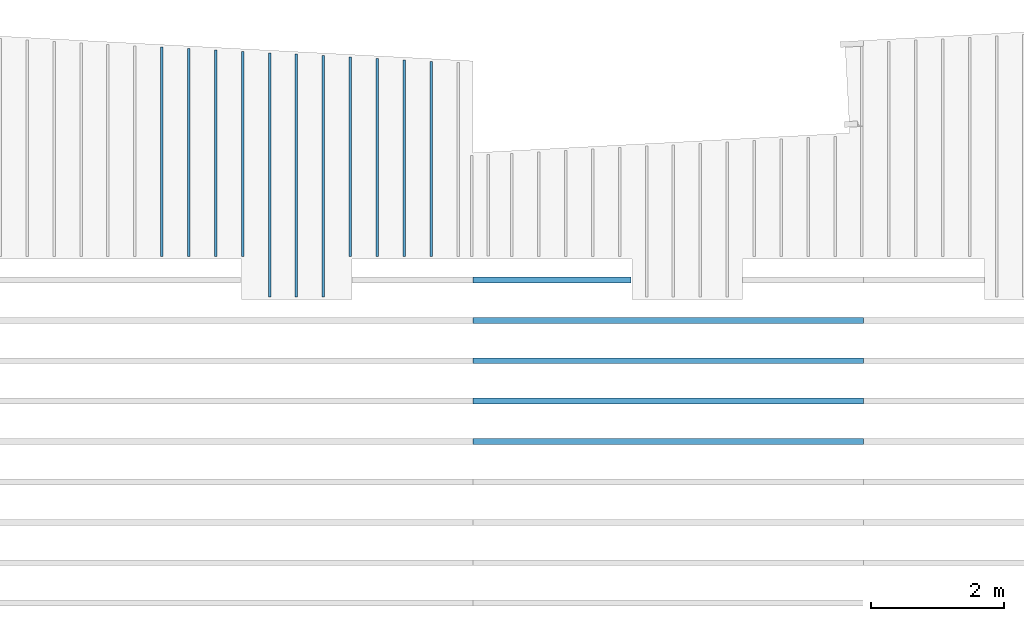
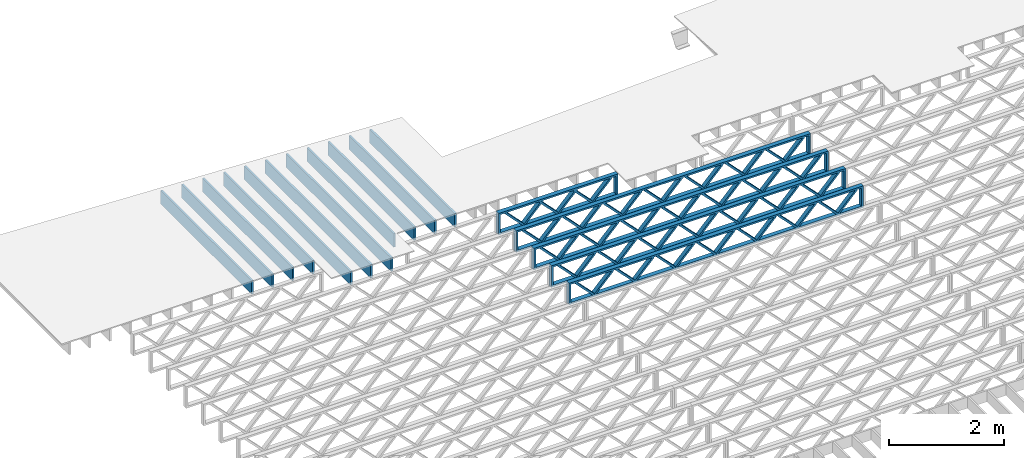
# One storey, part 4 of 12: 16 beams, 2 elements without a shape of their own.
"""IFC4 building model written with IfcOpenShell, lengths in feet."""

import ifcopenshell
import ifcopenshell.guid

model = None  # the IFC model being written
_history = None  # IfcOwnerHistory: only IFC2X3 demands one
_inside = {}  # id of a spatial element -> (the spatial element, [elements in it])
_under = {}  # id of a project, library or spatial element -> (it, [spatial elements below it])
_declared = {}  # id of a project -> (the project, [libraries it declares])
_typed = {}  # id of a type object -> (the type object, [elements of that type])
_made_of = {}  # id of a material, layer set ... -> (it, [elements and type objects made of it])


def new_model(schema):
    """Start an empty IFC model of exactly this schema.

    Asked for "IFC4X3", IfcOpenShell would pick the latest addendum, in which some entities
    have other attributes; the version numbers below select the first issue.
    IFC2X3 requires an IfcOwnerHistory on every rooted entity: one is made here for all.
    """
    global model, _history
    if schema == "IFC4X3":
        model = ifcopenshell.file(schema_version=(4, 3, 0, 0))
    else:
        model = ifcopenshell.file(schema=schema)
    _inside.clear()
    _under.clear()
    _declared.clear()
    _typed.clear()
    _made_of.clear()
    _history = None
    if model.schema == "IFC2X3":
        org = make("IfcOrganization", Name="unknown")
        user = make(
            "IfcPersonAndOrganization",
            ThePerson=make("IfcPerson", FamilyName="unknown"),
            TheOrganization=org,
        )
        app = make(
            "IfcApplication",
            ApplicationDeveloper=org,
            Version="unknown",
            ApplicationFullName="unknown",
            ApplicationIdentifier="unknown",
        )
        _history = make(
            "IfcOwnerHistory",
            OwningUser=user,
            OwningApplication=app,
            ChangeAction="ADDED",
            CreationDate=0,
        )
    return model


def make(cls, **values):
    """One entity of the class cls with the attributes given. An attribute that is None is left unset."""
    return model.create_entity(
        cls, **{name: value for name, value in values.items() if value is not None}
    )


def entity(cls, *values):
    """Any entity or typed value of the class cls, its attributes in the order of the schema. None: left unset."""
    e = model.create_entity(cls)
    for i, value in enumerate(values):
        if value is not None:
            e[i] = value
    return e


def rooted(cls, **values):
    """An entity with a GlobalId (a new one), such as an element, a storey or a relation."""
    return make(cls, GlobalId=ifcopenshell.guid.new(), OwnerHistory=_history, **values)


def si_unit(unit_type, name, prefix=None):
    """IfcSIUnit, for example si_unit("LENGTHUNIT", "METRE", prefix="MILLI")."""
    return make("IfcSIUnit", UnitType=unit_type, Prefix=prefix, Name=name)


def converted_unit(unit_type, name, factor, base, dimensions=None, offset=None):
    """IfcConversionBasedUnit, such as the inch: factor (a typed value) times the base unit."""
    return make(
        "IfcConversionBasedUnit"
        if offset is None
        else "IfcConversionBasedUnitWithOffset",
        ConversionOffset=offset,
        Dimensions=None
        if dimensions is None
        else entity("IfcDimensionalExponents", *dimensions),
        UnitType=unit_type,
        Name=name,
        ConversionFactor=make(
            "IfcMeasureWithUnit", ValueComponent=factor, UnitComponent=base
        ),
    )


def derived_unit(unit_type, elements):
    """IfcDerivedUnit: a product of units, each with its exponent."""
    return make(
        "IfcDerivedUnit",
        Elements=[
            make("IfcDerivedUnitElement", Unit=unit, Exponent=power)
            for unit, power in elements
        ],
        UnitType=unit_type,
    )


def assignment(units):
    """IfcUnitAssignment: the units of a project."""
    return None if units is None else make("IfcUnitAssignment", Units=units)


def point(xyz):
    """IfcCartesianPoint."""
    return None if xyz is None else make("IfcCartesianPoint", Coordinates=xyz)


def direction(xyz):
    """IfcDirection."""
    return None if xyz is None else make("IfcDirection", DirectionRatios=xyz)


def frame(location, z_axis=None, x_axis=None):
    """IfcAxis2Placement3D, a coordinate frame: its origin and axes. An axis left out is left unset."""
    return make(
        "IfcAxis2Placement3D",
        Location=point(location),
        Axis=direction(z_axis),
        RefDirection=direction(x_axis),
    )


def frame_2d(location, x_axis=None):
    """IfcAxis2Placement2D, a coordinate frame in the plane: its origin and x axis."""
    return make(
        "IfcAxis2Placement2D", Location=point(location), RefDirection=direction(x_axis)
    )


def origin():
    """The frame at (0, 0, 0) with its axes left unset."""
    return frame((0.0, 0.0, 0.0))


def origin_2d_with_axis():
    """The frame at (0, 0) in the plane with the x axis (1, 0) written out."""
    return frame_2d((0.0, 0.0), x_axis=(1.0, 0.0))


def place(relative_to, where):
    """IfcLocalPlacement: puts the frame where relative to a parent placement (None: the world)."""
    return make(
        "IfcLocalPlacement", PlacementRelTo=relative_to, RelativePlacement=where
    )


def context(
    kind, dimensions, precision=None, world=None, true_north=None, identifier=None
):
    """IfcGeometricRepresentationContext, for example the 3D "Model" context."""
    return make(
        "IfcGeometricRepresentationContext",
        ContextIdentifier=identifier,
        ContextType=kind,
        CoordinateSpaceDimension=dimensions,
        Precision=precision,
        WorldCoordinateSystem=world,
        TrueNorth=true_north,
    )


def subcontext(parent, identifier, kind, view, scale=None):
    """IfcGeometricRepresentationSubContext, for example "Body" below "Model"."""
    return make(
        "IfcGeometricRepresentationSubContext",
        ContextIdentifier=identifier,
        ContextType=kind,
        ParentContext=parent,
        TargetScale=scale,
        TargetView=view,
    )


def project(units=None, contexts=None):
    """IfcProject with its units and contexts."""
    return rooted(
        "IfcProject",
        Name="project",
        RepresentationContexts=contexts,
        UnitsInContext=assignment(units),
    )


def spatial(cls, under=None, at=None, **own):
    """A site, building, storey or space (cls), placed at a placement, below another one or the project."""
    s = rooted(cls, ObjectPlacement=at, **own)
    if under is not None:
        _under.setdefault(under.id(), (under, []))[1].append(s)
    return s


def profile(cls, at=None, kind="AREA", **sizes):
    """A parametric profile (cls). Its sizes go by their IFC names, for example OverallWidth=200.0."""
    return make(cls, ProfileType=kind, Position=at, **sizes)


def rectangle(**sizes):
    """IfcRectangleProfileDef."""
    return profile("IfcRectangleProfileDef", **sizes)


def extrude(swept, where, along, depth):
    """IfcExtrudedAreaSolid: the profile swept, set in the frame where, extruded along a direction by depth."""
    return make(
        "IfcExtrudedAreaSolid",
        SweptArea=swept,
        Position=where,
        ExtrudedDirection=direction(along),
        Depth=depth,
    )


def shape(context_of_items, identifier, shape_type, items):
    """IfcShapeRepresentation: the items that make up one representation, for example the "Body"."""
    return make(
        "IfcShapeRepresentation",
        ContextOfItems=context_of_items,
        RepresentationIdentifier=identifier,
        RepresentationType=shape_type,
        Items=items,
    )


def source(mapping_origin, context_of_items, identifier, shape_type, items):
    """IfcRepresentationMap: a shape defined once, which mapped items show again and again."""
    return make(
        "IfcRepresentationMap",
        MappingOrigin=mapping_origin,
        MappedRepresentation=shape(context_of_items, identifier, shape_type, items),
    )


def transform(
    local_origin,
    x_axis=None,
    y_axis=None,
    z_axis=None,
    scale=None,
    scale2=None,
    scale3=None,
    uniform=True,
):
    """IfcCartesianTransformationOperator3D, or its non-uniform kind. x_axis, y_axis, z_axis: its Axis1, 2, 3."""
    if uniform:
        return make(
            "IfcCartesianTransformationOperator3D",
            Axis1=direction(x_axis),
            Axis2=direction(y_axis),
            LocalOrigin=point(local_origin),
            Scale=scale,
            Axis3=direction(z_axis),
        )
    return make(
        "IfcCartesianTransformationOperator3DnonUniform",
        Axis1=direction(x_axis),
        Axis2=direction(y_axis),
        LocalOrigin=point(local_origin),
        Scale=scale,
        Axis3=direction(z_axis),
        Scale2=scale2,
        Scale3=scale3,
    )


def mapped(mapping_source, mapping_target):
    """IfcMappedItem: shows the shape of a source again, moved by a transform."""
    return make(
        "IfcMappedItem", MappingSource=mapping_source, MappingTarget=mapping_target
    )


def material(Name=None, Category=None):
    """IfcMaterial."""
    return make("IfcMaterial", Name=Name, Category=Category)


def material_profile(
    of_material, cross_section, Name=None, Category=None, Priority=None
):
    """IfcMaterialProfile: a cross section and its material."""
    return make(
        "IfcMaterialProfile",
        Name=Name,
        Material=of_material,
        Profile=cross_section,
        Priority=Priority,
        Category=Category,
    )


def profile_set(profiles, Name=None, composite=None):
    """IfcMaterialProfileSet."""
    return make(
        "IfcMaterialProfileSet",
        Name=Name,
        MaterialProfiles=profiles,
        CompositeProfile=composite,
    )


def profile_usage(for_profile_set, cardinal=None, extent=None):
    """IfcMaterialProfileSetUsage: how a profile set lies along its element."""
    return make(
        "IfcMaterialProfileSetUsage",
        ForProfileSet=for_profile_set,
        CardinalPoint=cardinal,
        ReferenceExtent=extent,
    )


def made_of(thing, what):
    """Note that an element or type object is made of a material, layer set ...; save() writes the relation."""
    if what is not None:
        _made_of.setdefault(what.id(), (what, []))[1].append(thing)
    return thing


def type_object(cls, material=None, **own):
    """A type object (cls), such as IfcWallType, which elements share."""
    return made_of(rooted(cls, **own), material)


def type_shapes(of_type, sources):
    """Give a type object the sources (RepresentationMaps) that its elements show as mapped items."""
    of_type.RepresentationMaps = sources


def element(
    cls,
    number,
    at=None,
    inside=None,
    cuts=None,
    type_object=None,
    material=None,
    context=None,
    identifier="Body",
    shape_type=None,
    held_by="IfcProductDefinitionShape",
    body=None,
    shapes=None,
    **own,
):
    """One element of the class cls, such as IfcWall. Its Tag is "e" and its number.

    at: its placement. inside: the storey or other place that contains it. cuts: it is an
    opening in that element (IfcRelVoidsElement). A single representation is given by context,
    identifier, shape_type and body (its items); several are given by shapes. held_by: the class
    of the entity that holds the representations. save() writes the other relations.
    """
    e = rooted(cls, Tag="e%d" % number, ObjectPlacement=at, **own)
    if body is not None:
        shapes = [shape(context, identifier, shape_type, body)]
    if shapes is not None:
        e.Representation = make(held_by, Representations=shapes)
    if inside is not None:
        _inside.setdefault(inside.id(), (inside, []))[1].append(e)
    if cuts is not None:
        rooted(
            "IfcRelVoidsElement", RelatingBuildingElement=cuts, RelatedOpeningElement=e
        )
    if type_object is not None:
        _typed.setdefault(type_object.id(), (type_object, []))[1].append(e)
    return made_of(e, material)


def aggregate(whole, parts):
    """IfcRelAggregates: a whole, such as a stair, and the parts it consists of."""
    return rooted("IfcRelAggregates", RelatingObject=whole, RelatedObjects=parts)


def save(model, path):
    """Write the relations noted so far, then the file.

    IfcRelAggregates (storeys below a building ...), IfcRelContainedInSpatialStructure (elements
    in a storey), IfcRelDefinesByType, IfcRelAssociatesMaterial and IfcRelDeclares: one each for
    every whole, place, type object, material and project.
    """
    for whole, parts in _under.values():
        aggregate(whole, parts)
    for where, things in _inside.values():
        rooted(
            "IfcRelContainedInSpatialStructure",
            RelatedElements=things,
            RelatingStructure=where,
        )
    for kind, things in _typed.values():
        rooted("IfcRelDefinesByType", RelatedObjects=things, RelatingType=kind)
    for what, things in _made_of.values():
        rooted("IfcRelAssociatesMaterial", RelatedObjects=things, RelatingMaterial=what)
    for by, libraries in _declared.values():
        rooted("IfcRelDeclares", RelatingContext=by, RelatedDefinitions=libraries)
    model.write(path)


model = new_model("IFC4")

# Units and contexts
model_context = context("Model", 3, precision=0.0001, world=origin(), true_north=direction((6.12303176911189e-17, 1.0)))
body_context = subcontext(model_context, "Body", "Model", "MODEL_VIEW")
ifc_project = project(units=[converted_unit("LENGTHUNIT", "FOOT", entity("IfcRatioMeasure", 0.3048), si_unit("LENGTHUNIT", "METRE"), dimensions=[1, 0, 0, 0, 0, 0, 0]), converted_unit("AREAUNIT", "SQUARE FOOT", entity("IfcRatioMeasure", 0.09290304), si_unit("AREAUNIT", "SQUARE_METRE"), dimensions=[2, 0, 0, 0, 0, 0, 0]), converted_unit("VOLUMEUNIT", "CUBIC FOOT", entity("IfcRatioMeasure", 0.028316846592), si_unit("VOLUMEUNIT", "CUBIC_METRE"), dimensions=[3, 0, 0, 0, 0, 0, 0]), converted_unit("PLANEANGLEUNIT", "DEGREE", entity("IfcRatioMeasure", 0.0174532925199433), si_unit("PLANEANGLEUNIT", "RADIAN"), dimensions=[0, 0, 0, 0, 0, 0, 0]), si_unit("MASSUNIT", "GRAM", prefix="KILO"), derived_unit("MASSDENSITYUNIT", [(si_unit("MASSUNIT", "GRAM", prefix="KILO"), 1), (si_unit("LENGTHUNIT", "METRE"), -3)]), derived_unit("MOMENTOFINERTIAUNIT", [(si_unit("LENGTHUNIT", "METRE"), 4)]), si_unit("TIMEUNIT", "SECOND"), si_unit("FREQUENCYUNIT", "HERTZ"), si_unit("THERMODYNAMICTEMPERATUREUNIT", "DEGREE_CELSIUS"), derived_unit("THERMALTRANSMITTANCEUNIT", [(si_unit("MASSUNIT", "GRAM", prefix="KILO"), 1), (si_unit("THERMODYNAMICTEMPERATUREUNIT", "KELVIN"), -1), (si_unit("TIMEUNIT", "SECOND"), -3)]), derived_unit("VOLUMETRICFLOWRATEUNIT", [(si_unit("LENGTHUNIT", "METRE"), 3), (si_unit("TIMEUNIT", "SECOND"), -1)]), si_unit("ELECTRICCURRENTUNIT", "AMPERE"), si_unit("ELECTRICVOLTAGEUNIT", "VOLT"), si_unit("POWERUNIT", "WATT"), si_unit("FORCEUNIT", "NEWTON"), si_unit("ILLUMINANCEUNIT", "LUX"), si_unit("LUMINOUSFLUXUNIT", "LUMEN"), si_unit("LUMINOUSINTENSITYUNIT", "CANDELA"), derived_unit("USERDEFINED", [(si_unit("MASSUNIT", "GRAM", prefix="KILO"), -1), (si_unit("LENGTHUNIT", "METRE"), -2), (si_unit("TIMEUNIT", "SECOND"), 3), (si_unit("LUMINOUSFLUXUNIT", "LUMEN"), 1)]), derived_unit("LINEARVELOCITYUNIT", [(si_unit("LENGTHUNIT", "METRE"), 1), (si_unit("TIMEUNIT", "SECOND"), -1)]), si_unit("PRESSUREUNIT", "PASCAL"), derived_unit("USERDEFINED", [(si_unit("LENGTHUNIT", "METRE"), -2), (si_unit("MASSUNIT", "GRAM", prefix="KILO"), 1), (si_unit("TIMEUNIT", "SECOND"), -2)]), derived_unit("LINEARFORCEUNIT", [(si_unit("MASSUNIT", "GRAM", prefix="KILO"), 1), (si_unit("LENGTHUNIT", "METRE"), 1), (si_unit("TIMEUNIT", "SECOND"), -2), (si_unit("LENGTHUNIT", "METRE"), -1)]), derived_unit("PLANARFORCEUNIT", [(si_unit("MASSUNIT", "GRAM", prefix="KILO"), 1), (si_unit("LENGTHUNIT", "METRE"), 1), (si_unit("TIMEUNIT", "SECOND"), -2), (si_unit("LENGTHUNIT", "METRE"), -2)])], contexts=[model_context])

# Site, building, storey
site_placement = place(None, origin())
site = spatial("IfcSite", under=ifc_project, at=site_placement, CompositionType="ELEMENT")
building_placement = place(site_placement, origin())
building = spatial("IfcBuilding", under=site, at=building_placement, CompositionType="ELEMENT")
storey_placement = place(building_placement, frame((0.0, 0.0, 21.46875)))
storey = spatial("IfcBuildingStorey", under=building, at=storey_placement, Name="3RD FLOOR", CompositionType="ELEMENT", Elevation=21.46875)

# Assembly, beams
assembly_1_placement = place(storey_placement, origin())
assembly_1 = element("IfcElementAssembly", 1, at=assembly_1_placement, inside=storey, Name="Structural Beam System:Structural Framing System", ObjectType="Structural Beam System:Structural Framing System", AssemblyPlace="NOTDEFINED", PredefinedType="BEAM_GRID")
ifc_material_1 = material(Name="WOOD TRUSS", Category="Materials")
ifc_material_profile_1 = material_profile(ifc_material_1, rectangle(XDim=1.73473973950632, YDim=0.125, at=frame_2d((-1.11022302462516e-16, 8.32667268468867e-17), x_axis=(1.0, 0.0))))
ifc_material_profile_2 = material_profile(ifc_material_1, rectangle(XDim=1.73473973950633, YDim=0.125, at=frame_2d((-1.11022302462516e-16, 8.32667268468867e-17), x_axis=(1.0, 0.0))))
ifc_material_profile_3 = material_profile(ifc_material_1, rectangle(XDim=1.73473973950632, YDim=0.125, at=frame_2d((-5.55111512312578e-17, 1.38777878078145e-16), x_axis=(1.0, 0.0))))
ifc_material_profile_4 = material_profile(ifc_material_1, rectangle(XDim=1.73473973950633, YDim=0.125, at=frame_2d((-1.11022302462516e-16, 8.32667268468867e-17), x_axis=(1.0, 0.0))))
ifc_material_profile_5 = material_profile(ifc_material_1, rectangle(XDim=1.73473973950632, YDim=0.125, at=frame_2d((-1.11022302462516e-16, 8.32667268468867e-17), x_axis=(1.0, 0.0))))
ifc_material_profile_6 = material_profile(ifc_material_1, rectangle(XDim=1.73473973950633, YDim=0.125, at=frame_2d((-2.77555756156289e-16, 3.05311331771918e-16), x_axis=(1.0, 0.0))))
ifc_material_profile_7 = material_profile(ifc_material_1, rectangle(XDim=1.73473973950632, YDim=0.124999999999999, at=frame_2d((-3.88578058618805e-16, -2.4980018054066e-16), x_axis=(1.0, 0.0))))
ifc_material_profile_8 = material_profile(ifc_material_1, rectangle(XDim=1.73473973950633, YDim=0.125, at=frame_2d((2.77555756156289e-16, -3.05311331771918e-16), x_axis=(1.0, 0.0))))
ifc_material_profile_9 = material_profile(ifc_material_1, rectangle(XDim=1.73473973950632, YDim=0.124999999999999, at=frame_2d((-1.11022302462516e-16, 8.32667268468867e-17), x_axis=(1.0, 0.0))))
ifc_material_profile_10 = material_profile(ifc_material_1, rectangle(XDim=1.73473973950633, YDim=0.125, at=origin_2d_with_axis()))
ifc_material_profile_11 = material_profile(ifc_material_1, rectangle(XDim=0.124999999999982, YDim=0.291666666666668, at=origin_2d_with_axis()))
ifc_material_profile_12 = material_profile(ifc_material_1, rectangle(XDim=0.124999999999932, YDim=0.291666666666664, at=origin_2d_with_axis()))
ifc_material_profile_13 = material_profile(ifc_material_1, rectangle(XDim=1.25000000000002, YDim=0.29166666666667, at=origin_2d_with_axis()))
ifc_material_profile_14 = material_profile(ifc_material_1, rectangle(XDim=1.25000000000004, YDim=0.291666666666667, at=origin_2d_with_axis()))
ifc_profile_set_1 = profile_set([ifc_material_profile_1, ifc_material_profile_2, ifc_material_profile_3, ifc_material_profile_4, ifc_material_profile_5, ifc_material_profile_6, ifc_material_profile_7, ifc_material_profile_8, ifc_material_profile_9, ifc_material_profile_10, ifc_material_profile_11, ifc_material_profile_12, ifc_material_profile_13, ifc_material_profile_14])
ifc_profile_usage_1 = profile_usage(ifc_profile_set_1, cardinal=8)
beam_type_1 = type_object("IfcBeamType", PredefinedType="BEAM", material=ifc_profile_set_1)
shared_shape_1 = source(origin(), body_context, "Body", "SweptSolid", [
    extrude(rectangle(XDim=1.73473973950632, YDim=0.125, at=frame_2d((-5.55111512312578e-17, 1.38777878078145e-16), x_axis=(1.0, 0.0))), frame((0.625142936836962, -0.145833333333334, 0.0), z_axis=(0.0, 1.0, 0.0), x_axis=(0.693383046997606, 0.0, 0.720569184836762)), (0.0, 0.0, 1.0), 0.291666666666667),
    extrude(rectangle(XDim=1.73473973950633, YDim=0.125, at=frame_2d((-1.11022302462516e-16, 8.32667268468867e-17), x_axis=(1.0, 0.0))), frame((-0.625142936836309, -0.145833333333334, 0.0), z_axis=(0.0, 1.0, 0.0), x_axis=(0.69338304699761, 0.0, -0.720569184836758)), (0.0, 0.0, 1.0), 0.291666666666667),
    extrude(rectangle(XDim=1.73473973950632, YDim=0.125, at=frame_2d((-1.11022302462516e-16, 8.32667268468867e-17), x_axis=(1.0, 0.0))), frame((2.87514283803796, -0.145833333333334, 0.0), z_axis=(0.0, 1.0, 0.0), x_axis=(0.693383046997606, 0.0, 0.720569184836762)), (0.0, 0.0, 1.0), 0.291666666666667),
    extrude(rectangle(XDim=1.73473973950633, YDim=0.125, at=frame_2d((-1.11022302462516e-16, 8.32667268468867e-17), x_axis=(1.0, 0.0))), frame((1.62485696436469, -0.145833333333334, 0.0), z_axis=(0.0, 1.0, 0.0), x_axis=(0.69338304699761, 0.0, -0.720569184836758)), (0.0, 0.0, 1.0), 0.291666666666667),
    extrude(rectangle(XDim=1.73473973950632, YDim=0.125, at=frame_2d((-1.11022302462516e-16, 8.32667268468867e-17), x_axis=(1.0, 0.0))), frame((-1.62485696436403, -0.145833333333334, 0.0), z_axis=(0.0, 1.0, 0.0), x_axis=(0.693383046997606, 0.0, 0.720569184836762)), (0.0, 0.0, 1.0), 0.291666666666667),
    extrude(rectangle(XDim=1.73473973950633, YDim=0.125, at=origin_2d_with_axis()), frame((-2.87514283803731, -0.145833333333334, 0.0), z_axis=(0.0, 1.0, 0.0), x_axis=(0.69338304699761, 0.0, -0.720569184836758)), (0.0, 0.0, 1.0), 0.291666666666667),
    extrude(rectangle(XDim=0.124999999999982, YDim=0.291666666666668, at=origin_2d_with_axis()), frame((-3.91666656786758, 0.0, 0.687500000000054), z_axis=(1.0, 0.0, 0.0), x_axis=(0.0, 0.0, -1.0)), (0.0, 0.0, 1.0), 7.83333313573516),
    extrude(rectangle(XDim=0.124999999999932, YDim=0.291666666666664, at=origin_2d_with_axis()), frame((-3.91666656786737, 0.0, -0.687499999999984), z_axis=(1.0, 0.0, 0.0), x_axis=(0.0, 0.0, -1.0)), (0.0, 0.0, 1.0), 7.83333313573495),
    extrude(rectangle(XDim=1.25000000000002, YDim=0.29166666666667, at=origin_2d_with_axis()), frame((3.79166656786756, 0.0, 0.0), z_axis=(1.0, 0.0, 0.0), x_axis=(0.0, 0.0, -1.0)), (0.0, 0.0, 1.0), 0.12500000000002),
    extrude(rectangle(XDim=1.25000000000004, YDim=0.291666666666667, at=origin_2d_with_axis()), frame((-3.91666656786758, 0.0, 0.0), z_axis=(1.0, 0.0, 0.0), x_axis=(0.0, 0.0, -1.0)), (0.0, 0.0, 1.0), 0.125000000000023),
])
type_shapes(beam_type_1, [shared_shape_1])
beam_1_placement = place(assembly_1_placement, frame((-237.821493887522, 957.861934882651, -0.947916666666661)))
beam_1 = element("IfcBeam", 2, at=beam_1_placement, type_object=beam_type_1, material=ifc_profile_usage_1, PredefinedType="BEAM", context=body_context, shape_type="MappedRepresentation", body=[
    mapped(shared_shape_1, transform((0.0, 0.0, 0.0), scale=1.0)),
])
ifc_profile_usage_2 = profile_usage(ifc_profile_set_1, cardinal=8)
beam_type_2 = type_object("IfcBeamType", PredefinedType="BEAM", material=ifc_profile_set_1)
shared_shape_2 = source(origin(), body_context, "Body", "SweptSolid", [
    extrude(rectangle(XDim=1.73473973950632, YDim=0.124999999999999, at=frame_2d((5.55111512312578e-16, 7.21644966006352e-16), x_axis=(1.0, 0.0))), frame((5.95847627016997, -0.145833333333334, 0.0), z_axis=(0.0, 1.0, 0.0), x_axis=(0.693383046997606, 0.0, 0.720569184836762)), (0.0, 0.0, 1.0), 0.291666666666667),
    extrude(rectangle(XDim=1.73473973950633, YDim=0.125, at=origin_2d_with_axis()), frame((4.7081903964967, -0.145833333333334, 0.0), z_axis=(0.0, 1.0, 0.0), x_axis=(0.69338304699761, 0.0, -0.720569184836758)), (0.0, 0.0, 1.0), 0.291666666666666),
    extrude(rectangle(XDim=1.73473973950632, YDim=0.125, at=frame_2d((2.22044604925031e-16, 3.88578058618805e-16), x_axis=(1.0, 0.0))), frame((3.29180960350347, -0.145833333333334, 0.0), z_axis=(0.0, 1.0, 0.0), x_axis=(0.693383046997606, 0.0, 0.720569184836762)), (0.0, 0.0, 1.0), 0.291666666666667),
    extrude(rectangle(XDim=1.73473973950633, YDim=0.125, at=frame_2d((1.11022302462516e-16, -8.32667268468867e-17), x_axis=(1.0, 0.0))), frame((2.0415237298302, -0.145833333333334, 0.0), z_axis=(0.0, 1.0, 0.0), x_axis=(0.69338304699761, 0.0, -0.720569184836758)), (0.0, 0.0, 1.0), 0.291666666666667),
    extrude(rectangle(XDim=1.73473973950632, YDim=0.125, at=frame_2d((-5.55111512312578e-17, 1.38777878078145e-16), x_axis=(1.0, 0.0))), frame((0.625142936836964, -0.145833333333334, 0.0), z_axis=(0.0, 1.0, 0.0), x_axis=(0.693383046997606, 0.0, 0.720569184836762)), (0.0, 0.0, 1.0), 0.291666666666667),
    extrude(rectangle(XDim=1.73473973950633, YDim=0.125, at=frame_2d((-1.11022302462516e-16, 8.32667268468867e-17), x_axis=(1.0, 0.0))), frame((-0.625142936836306, -0.145833333333334, 0.0), z_axis=(0.0, 1.0, 0.0), x_axis=(0.69338304699761, 0.0, -0.720569184836758)), (0.0, 0.0, 1.0), 0.291666666666667),
    extrude(rectangle(XDim=1.73473973950632, YDim=0.125, at=frame_2d((-1.11022302462516e-16, 8.32667268468867e-17), x_axis=(1.0, 0.0))), frame((-2.04152372982954, -0.145833333333334, 0.0), z_axis=(0.0, 1.0, 0.0), x_axis=(0.693383046997606, 0.0, 0.720569184836762)), (0.0, 0.0, 1.0), 0.291666666666667),
    extrude(rectangle(XDim=1.73473973950633, YDim=0.125, at=origin_2d_with_axis()), frame((-3.29180960350281, -0.145833333333334, 0.0), z_axis=(0.0, 1.0, 0.0), x_axis=(0.69338304699761, 0.0, -0.720569184836758)), (0.0, 0.0, 1.0), 0.291666666666667),
    extrude(rectangle(XDim=1.73473973950632, YDim=0.124999999999999, at=frame_2d((-1.11022302462516e-16, 8.32667268468867e-17), x_axis=(1.0, 0.0))), frame((-4.70819039649604, -0.145833333333334, 0.0), z_axis=(0.0, 1.0, 0.0), x_axis=(0.693383046997606, 0.0, 0.720569184836762)), (0.0, 0.0, 1.0), 0.291666666666667),
    extrude(rectangle(XDim=1.73473973950633, YDim=0.125, at=frame_2d((-5.55111512312578e-16, 6.38378239159465e-16), x_axis=(1.0, 0.0))), frame((-5.95847627016931, -0.145833333333334, 0.0), z_axis=(0.0, 1.0, 0.0), x_axis=(0.69338304699761, 0.0, -0.720569184836758)), (0.0, 0.0, 1.0), 0.291666666666666),
    extrude(rectangle(XDim=1.73473973950632, YDim=0.125, at=frame_2d((-7.21644966006352e-16, -5.82867087928207e-16), x_axis=(1.0, 0.0))), frame((8.62514293683647, -0.145833333333334, 0.0), z_axis=(0.0, 1.0, 0.0), x_axis=(0.693383046997607, 0.0, 0.720569184836761)), (0.0, 0.0, 1.0), 0.291666666666667),
    extrude(rectangle(XDim=1.73473973950633, YDim=0.125, at=origin_2d_with_axis()), frame((7.3748570631632, -0.145833333333334, 0.0), z_axis=(0.0, 1.0, 0.0), x_axis=(0.69338304699761, 0.0, -0.720569184836758)), (0.0, 0.0, 1.0), 0.291666666666666),
    extrude(rectangle(XDim=1.73473973950632, YDim=0.124999999999999, at=frame_2d((-1.11022302462516e-16, 8.32667268468867e-17), x_axis=(1.0, 0.0))), frame((-7.37485706316255, -0.145833333333334, 0.0), z_axis=(0.0, 1.0, 0.0), x_axis=(0.693383046997606, 0.0, 0.720569184836762)), (0.0, 0.0, 1.0), 0.291666666666667),
    extrude(rectangle(XDim=1.73473973950633, YDim=0.125, at=origin_2d_with_axis()), frame((-8.62514293683582, -0.145833333333334, 0.0), z_axis=(0.0, 1.0, 0.0), x_axis=(0.69338304699761, 0.0, -0.720569184836758)), (0.0, 0.0, 1.0), 0.291666666666666),
    extrude(rectangle(XDim=0.124999999999982, YDim=0.291666666666668, at=origin_2d_with_axis()), frame((-9.66666666666609, 0.0, 0.687500000000054), z_axis=(1.0, 0.0, 0.0), x_axis=(0.0, 0.0, -1.0)), (0.0, 0.0, 1.0), 19.3333333333322),
    extrude(rectangle(XDim=0.124999999999932, YDim=0.291666666666664, at=origin_2d_with_axis()), frame((-9.66666666666588, 0.0, -0.687499999999984), z_axis=(1.0, 0.0, 0.0), x_axis=(0.0, 0.0, -1.0)), (0.0, 0.0, 1.0), 19.333333333332),
    extrude(rectangle(XDim=1.25000000000002, YDim=0.29166666666667, at=origin_2d_with_axis()), frame((9.54166666666607, 0.0, 0.0), z_axis=(1.0, 0.0, 0.0), x_axis=(0.0, 0.0, -1.0)), (0.0, 0.0, 1.0), 0.12500000000002),
    extrude(rectangle(XDim=1.25000000000004, YDim=0.291666666666667, at=origin_2d_with_axis()), frame((-9.66666666666609, 0.0, 0.0), z_axis=(1.0, 0.0, 0.0), x_axis=(0.0, 0.0, -1.0)), (0.0, 0.0, 1.0), 0.125000000000023),
])
type_shapes(beam_type_2, [shared_shape_2])
beam_2_placement = place(assembly_1_placement, frame((-232.071493788724, 955.861934882651, -0.947916666666661)))
beam_2 = element("IfcBeam", 3, at=beam_2_placement, type_object=beam_type_2, material=ifc_profile_usage_2, PredefinedType="BEAM", context=body_context, shape_type="MappedRepresentation", body=[
    mapped(shared_shape_2, transform((0.0, 0.0, 0.0), scale=1.0)),
])
ifc_profile_usage_3 = profile_usage(ifc_profile_set_1, cardinal=8)
beam_type_3 = type_object("IfcBeamType", PredefinedType="BEAM", material=ifc_profile_set_1)
shared_shape_3 = source(origin(), body_context, "Body", "SweptSolid", [
    extrude(rectangle(XDim=1.73473973950632, YDim=0.124999999999999, at=frame_2d((5.55111512312578e-16, 7.21644966006352e-16), x_axis=(1.0, 0.0))), frame((5.95847627016997, -0.145833333333334, 0.0), z_axis=(0.0, 1.0, 0.0), x_axis=(0.693383046997606, 0.0, 0.720569184836762)), (0.0, 0.0, 1.0), 0.291666666666667),
    extrude(rectangle(XDim=1.73473973950633, YDim=0.125, at=origin_2d_with_axis()), frame((4.7081903964967, -0.145833333333334, 0.0), z_axis=(0.0, 1.0, 0.0), x_axis=(0.69338304699761, 0.0, -0.720569184836758)), (0.0, 0.0, 1.0), 0.291666666666666),
    extrude(rectangle(XDim=1.73473973950632, YDim=0.125, at=frame_2d((2.22044604925031e-16, 3.88578058618805e-16), x_axis=(1.0, 0.0))), frame((3.29180960350347, -0.145833333333334, 0.0), z_axis=(0.0, 1.0, 0.0), x_axis=(0.693383046997606, 0.0, 0.720569184836762)), (0.0, 0.0, 1.0), 0.291666666666667),
    extrude(rectangle(XDim=1.73473973950633, YDim=0.125, at=frame_2d((1.11022302462516e-16, -8.32667268468867e-17), x_axis=(1.0, 0.0))), frame((2.0415237298302, -0.145833333333334, 0.0), z_axis=(0.0, 1.0, 0.0), x_axis=(0.69338304699761, 0.0, -0.720569184836758)), (0.0, 0.0, 1.0), 0.291666666666667),
    extrude(rectangle(XDim=1.73473973950632, YDim=0.125, at=frame_2d((-5.55111512312578e-17, 1.38777878078145e-16), x_axis=(1.0, 0.0))), frame((0.625142936836964, -0.145833333333334, 0.0), z_axis=(0.0, 1.0, 0.0), x_axis=(0.693383046997606, 0.0, 0.720569184836762)), (0.0, 0.0, 1.0), 0.291666666666667),
    extrude(rectangle(XDim=1.73473973950633, YDim=0.125, at=frame_2d((-1.11022302462516e-16, 8.32667268468867e-17), x_axis=(1.0, 0.0))), frame((-0.625142936836306, -0.145833333333334, 0.0), z_axis=(0.0, 1.0, 0.0), x_axis=(0.69338304699761, 0.0, -0.720569184836758)), (0.0, 0.0, 1.0), 0.291666666666667),
    extrude(rectangle(XDim=1.73473973950632, YDim=0.125, at=frame_2d((-1.11022302462516e-16, 8.32667268468867e-17), x_axis=(1.0, 0.0))), frame((-2.04152372982954, -0.145833333333334, 0.0), z_axis=(0.0, 1.0, 0.0), x_axis=(0.693383046997606, 0.0, 0.720569184836762)), (0.0, 0.0, 1.0), 0.291666666666667),
    extrude(rectangle(XDim=1.73473973950633, YDim=0.125, at=origin_2d_with_axis()), frame((-3.29180960350281, -0.145833333333334, 0.0), z_axis=(0.0, 1.0, 0.0), x_axis=(0.69338304699761, 0.0, -0.720569184836758)), (0.0, 0.0, 1.0), 0.291666666666667),
    extrude(rectangle(XDim=1.73473973950632, YDim=0.124999999999999, at=frame_2d((-1.11022302462516e-16, 8.32667268468867e-17), x_axis=(1.0, 0.0))), frame((-4.70819039649604, -0.145833333333334, 0.0), z_axis=(0.0, 1.0, 0.0), x_axis=(0.693383046997606, 0.0, 0.720569184836762)), (0.0, 0.0, 1.0), 0.291666666666667),
    extrude(rectangle(XDim=1.73473973950633, YDim=0.125, at=frame_2d((-5.55111512312578e-16, 6.38378239159465e-16), x_axis=(1.0, 0.0))), frame((-5.95847627016931, -0.145833333333334, 0.0), z_axis=(0.0, 1.0, 0.0), x_axis=(0.69338304699761, 0.0, -0.720569184836758)), (0.0, 0.0, 1.0), 0.291666666666666),
    extrude(rectangle(XDim=1.73473973950632, YDim=0.125, at=frame_2d((-7.21644966006352e-16, -5.82867087928207e-16), x_axis=(1.0, 0.0))), frame((8.62514293683647, -0.145833333333334, 0.0), z_axis=(0.0, 1.0, 0.0), x_axis=(0.693383046997607, 0.0, 0.720569184836761)), (0.0, 0.0, 1.0), 0.291666666666667),
    extrude(rectangle(XDim=1.73473973950633, YDim=0.125, at=origin_2d_with_axis()), frame((7.3748570631632, -0.145833333333334, 0.0), z_axis=(0.0, 1.0, 0.0), x_axis=(0.69338304699761, 0.0, -0.720569184836758)), (0.0, 0.0, 1.0), 0.291666666666666),
    extrude(rectangle(XDim=1.73473973950632, YDim=0.124999999999999, at=frame_2d((-1.11022302462516e-16, 8.32667268468867e-17), x_axis=(1.0, 0.0))), frame((-7.37485706316255, -0.145833333333334, 0.0), z_axis=(0.0, 1.0, 0.0), x_axis=(0.693383046997606, 0.0, 0.720569184836762)), (0.0, 0.0, 1.0), 0.291666666666667),
    extrude(rectangle(XDim=1.73473973950633, YDim=0.125, at=origin_2d_with_axis()), frame((-8.62514293683582, -0.145833333333334, 0.0), z_axis=(0.0, 1.0, 0.0), x_axis=(0.69338304699761, 0.0, -0.720569184836758)), (0.0, 0.0, 1.0), 0.291666666666666),
    extrude(rectangle(XDim=0.124999999999982, YDim=0.291666666666668, at=origin_2d_with_axis()), frame((-9.66666666666609, 0.0, 0.687500000000054), z_axis=(1.0, 0.0, 0.0), x_axis=(0.0, 0.0, -1.0)), (0.0, 0.0, 1.0), 19.3333333333322),
    extrude(rectangle(XDim=0.124999999999932, YDim=0.291666666666664, at=origin_2d_with_axis()), frame((-9.66666666666588, 0.0, -0.687499999999984), z_axis=(1.0, 0.0, 0.0), x_axis=(0.0, 0.0, -1.0)), (0.0, 0.0, 1.0), 19.333333333332),
    extrude(rectangle(XDim=1.25000000000002, YDim=0.29166666666667, at=origin_2d_with_axis()), frame((9.54166666666607, 0.0, 0.0), z_axis=(1.0, 0.0, 0.0), x_axis=(0.0, 0.0, -1.0)), (0.0, 0.0, 1.0), 0.12500000000002),
    extrude(rectangle(XDim=1.25000000000004, YDim=0.291666666666667, at=origin_2d_with_axis()), frame((-9.66666666666609, 0.0, 0.0), z_axis=(1.0, 0.0, 0.0), x_axis=(0.0, 0.0, -1.0)), (0.0, 0.0, 1.0), 0.125000000000023),
])
type_shapes(beam_type_3, [shared_shape_3])
beam_3_placement = place(assembly_1_placement, frame((-232.071493788724, 953.861934882651, -0.947916666666661)))
beam_3 = element("IfcBeam", 4, at=beam_3_placement, type_object=beam_type_3, material=ifc_profile_usage_3, PredefinedType="BEAM", context=body_context, shape_type="MappedRepresentation", body=[
    mapped(shared_shape_3, transform((0.0, 0.0, 0.0), scale=1.0)),
])
ifc_profile_usage_4 = profile_usage(ifc_profile_set_1, cardinal=8)
beam_4_placement = place(assembly_1_placement, frame((-232.071493788724, 951.861934882651, -0.947916666666661)))
beam_4 = element("IfcBeam", 5, at=beam_4_placement, type_object=beam_type_3, material=ifc_profile_usage_4, PredefinedType="BEAM", context=body_context, shape_type="MappedRepresentation", body=[
    mapped(shared_shape_3, transform((0.0, 0.0, 0.0), scale=1.0)),
])
ifc_profile_usage_5 = profile_usage(ifc_profile_set_1, cardinal=8)
beam_5_placement = place(assembly_1_placement, frame((-232.071493788724, 949.861934882651, -0.947916666666661)))
beam_5 = element("IfcBeam", 6, at=beam_5_placement, type_object=beam_type_3, material=ifc_profile_usage_5, PredefinedType="BEAM", context=body_context, shape_type="MappedRepresentation", body=[
    mapped(shared_shape_3, transform((0.0, 0.0, 0.0), scale=1.0)),
])
aggregate(assembly_1, [beam_1, beam_2, beam_3, beam_4, beam_5])

assembly_2_placement = place(storey_placement, origin())
assembly_2 = element("IfcElementAssembly", 7, at=assembly_2_placement, inside=storey, Name="Structural Beam System:Structural Framing System", ObjectType="Structural Beam System:Structural Framing System", AssemblyPlace="NOTDEFINED", PredefinedType="BEAM_GRID")
ifc_material_2 = material(Category="Materials")
ifc_material_profile_15 = material_profile(ifc_material_2, rectangle(XDim=0.9375, YDim=0.125000000000011, at=origin_2d_with_axis()))
ifc_profile_set_2 = profile_set([ifc_material_profile_15])
ifc_profile_usage_6 = profile_usage(ifc_profile_set_2, cardinal=8)
beam_type_4 = type_object("IfcBeamType", PredefinedType="BEAM", material=ifc_profile_set_2)
shared_shape_4 = source(origin(), body_context, "Body", "SweptSolid", [
    extrude(rectangle(XDim=0.9375, YDim=0.125000000000011, at=origin_2d_with_axis()), frame((-5.1810230302778, 0.0, 0.0), z_axis=(1.0, 0.0, 0.0), x_axis=(0.0, 0.0, -1.0)), (0.0, 0.0, 1.0), 10.3620460605556),
])
type_shapes(beam_type_4, [shared_shape_4])
beam_6_placement = place(assembly_2_placement, frame((-257.144289386034, 964.209624099342, -0.729166666666714), z_axis=(0.0, 0.0, 1.0), x_axis=(0.0, 1.0, 0.0)))
beam_6 = element("IfcBeam", 8, at=beam_6_placement, type_object=beam_type_4, material=ifc_profile_usage_6, PredefinedType="BEAM", context=body_context, shape_type="MappedRepresentation", body=[
    mapped(shared_shape_4, transform((0.0, 0.0, 0.0), scale=1.0)),
])
ifc_profile_usage_7 = profile_usage(ifc_profile_set_2, cardinal=8)
beam_type_5 = type_object("IfcBeamType", PredefinedType="BEAM", material=ifc_profile_set_2)
shared_shape_5 = source(origin(), body_context, "Body", "SweptSolid", [
    extrude(rectangle(XDim=0.9375, YDim=0.125000000000011, at=origin_2d_with_axis()), frame((-5.14608451075577, 0.0, 0.0), z_axis=(1.0, 0.0, 0.0), x_axis=(0.0, 0.0, -1.0)), (0.0, 0.0, 1.0), 10.2921690215115),
])
type_shapes(beam_type_5, [shared_shape_5])
beam_7_placement = place(assembly_2_placement, frame((-255.810956052701, 964.17468557982, -0.729166666666714), z_axis=(0.0, 0.0, 1.0), x_axis=(0.0, 1.0, 0.0)))
beam_7 = element("IfcBeam", 9, at=beam_7_placement, type_object=beam_type_5, material=ifc_profile_usage_7, PredefinedType="BEAM", context=body_context, shape_type="MappedRepresentation", body=[
    mapped(shared_shape_5, transform((0.0, 0.0, 0.0), scale=1.0)),
])
ifc_profile_usage_8 = profile_usage(ifc_profile_set_2, cardinal=8)
beam_type_6 = type_object("IfcBeamType", PredefinedType="BEAM", material=ifc_profile_set_2)
shared_shape_6 = source(origin(), body_context, "Body", "SweptSolid", [
    extrude(rectangle(XDim=0.9375, YDim=0.125000000000011, at=origin_2d_with_axis()), frame((-5.11114599123374, 0.0, 0.0), z_axis=(1.0, 0.0, 0.0), x_axis=(0.0, 0.0, -1.0)), (0.0, 0.0, 1.0), 10.2222919824675),
])
type_shapes(beam_type_6, [shared_shape_6])
beam_8_placement = place(assembly_2_placement, frame((-254.477622719368, 964.139747060298, -0.729166666666714), z_axis=(0.0, 0.0, 1.0), x_axis=(0.0, 1.0, 0.0)))
beam_8 = element("IfcBeam", 10, at=beam_8_placement, type_object=beam_type_6, material=ifc_profile_usage_8, PredefinedType="BEAM", context=body_context, shape_type="MappedRepresentation", body=[
    mapped(shared_shape_6, transform((0.0, 0.0, 0.0), scale=1.0)),
])
ifc_profile_usage_9 = profile_usage(ifc_profile_set_2, cardinal=8)
beam_type_7 = type_object("IfcBeamType", PredefinedType="BEAM", material=ifc_profile_set_2)
shared_shape_7 = source(origin(), body_context, "Body", "SweptSolid", [
    extrude(rectangle(XDim=0.9375, YDim=0.125000000000011, at=origin_2d_with_axis()), frame((-5.07620747171171, 0.0, 0.0), z_axis=(1.0, 0.0, 0.0), x_axis=(0.0, 0.0, -1.0)), (0.0, 0.0, 1.0), 10.1524149434234),
])
type_shapes(beam_type_7, [shared_shape_7])
beam_9_placement = place(assembly_2_placement, frame((-253.144289386034, 964.104808540776, -0.729166666666714), z_axis=(0.0, 0.0, 1.0), x_axis=(0.0, 1.0, 0.0)))
beam_9 = element("IfcBeam", 11, at=beam_9_placement, type_object=beam_type_7, material=ifc_profile_usage_9, PredefinedType="BEAM", context=body_context, shape_type="MappedRepresentation", body=[
    mapped(shared_shape_7, transform((0.0, 0.0, 0.0), scale=1.0)),
])
ifc_profile_usage_10 = profile_usage(ifc_profile_set_2, cardinal=8)
beam_type_8 = type_object("IfcBeamType", PredefinedType="BEAM", material=ifc_profile_set_2)
shared_shape_8 = source(origin(), body_context, "Body", "SweptSolid", [
    extrude(rectangle(XDim=0.9375, YDim=0.125000000000011, at=origin_2d_with_axis()), frame((-6.04081137653259, 0.0, 0.0), z_axis=(1.0, 0.0, 0.0), x_axis=(0.0, 0.0, -1.0)), (0.0, 0.0, 1.0), 12.0816227530652),
])
type_shapes(beam_type_8, [shared_shape_8])
beam_10_placement = place(assembly_2_placement, frame((-251.810956062631, 963.070327597432, -0.729166666666714), z_axis=(0.0, 0.0, 1.0), x_axis=(0.0, 1.0, 0.0)))
beam_10 = element("IfcBeam", 12, at=beam_10_placement, type_object=beam_type_8, material=ifc_profile_usage_10, PredefinedType="BEAM", context=body_context, shape_type="MappedRepresentation", body=[
    mapped(shared_shape_8, transform((0.0, 0.0, 0.0), scale=1.0)),
])
ifc_profile_usage_11 = profile_usage(ifc_profile_set_2, cardinal=8)
beam_type_9 = type_object("IfcBeamType", PredefinedType="BEAM", material=ifc_profile_set_2)
shared_shape_9 = source(origin(), body_context, "Body", "SweptSolid", [
    extrude(rectangle(XDim=0.9375, YDim=0.125000000000011, at=origin_2d_with_axis()), frame((-6.00587285701056, 0.0, 0.0), z_axis=(1.0, 0.0, 0.0), x_axis=(0.0, 0.0, -1.0)), (0.0, 0.0, 1.0), 12.0117457140211),
])
type_shapes(beam_type_9, [shared_shape_9])
beam_11_placement = place(assembly_2_placement, frame((-250.477622729298, 963.03538907791, -0.729166666666714), z_axis=(0.0, 0.0, 1.0), x_axis=(0.0, 1.0, 0.0)))
beam_11 = element("IfcBeam", 13, at=beam_11_placement, type_object=beam_type_9, material=ifc_profile_usage_11, PredefinedType="BEAM", context=body_context, shape_type="MappedRepresentation", body=[
    mapped(shared_shape_9, transform((0.0, 0.0, 0.0), scale=1.0)),
])
ifc_profile_usage_12 = profile_usage(ifc_profile_set_2, cardinal=8)
beam_type_10 = type_object("IfcBeamType", PredefinedType="BEAM", material=ifc_profile_set_2)
shared_shape_10 = source(origin(), body_context, "Body", "SweptSolid", [
    extrude(rectangle(XDim=0.9375, YDim=0.125000000000011, at=origin_2d_with_axis()), frame((-5.97093433748853, 0.0, 0.0), z_axis=(1.0, 0.0, 0.0), x_axis=(0.0, 0.0, -1.0)), (0.0, 0.0, 1.0), 11.9418686749771),
])
type_shapes(beam_type_10, [shared_shape_10])
beam_12_placement = place(assembly_2_placement, frame((-249.144289395965, 963.000450558388, -0.729166666666714), z_axis=(0.0, 0.0, 1.0), x_axis=(0.0, 1.0, 0.0)))
beam_12 = element("IfcBeam", 14, at=beam_12_placement, type_object=beam_type_10, material=ifc_profile_usage_12, PredefinedType="BEAM", context=body_context, shape_type="MappedRepresentation", body=[
    mapped(shared_shape_10, transform((0.0, 0.0, 0.0), scale=1.0)),
])
ifc_profile_usage_13 = profile_usage(ifc_profile_set_2, cardinal=8)
beam_type_11 = type_object("IfcBeamType", PredefinedType="BEAM", material=ifc_profile_set_2)
shared_shape_11 = source(origin(), body_context, "Body", "SweptSolid", [
    extrude(rectangle(XDim=0.9375, YDim=0.125000000000011, at=origin_2d_with_axis()), frame((-4.93599383169669, 0.0, 0.0), z_axis=(1.0, 0.0, 0.0), x_axis=(0.0, 0.0, -1.0)), (0.0, 0.0, 1.0), 9.87198766339338),
])
type_shapes(beam_type_11, [shared_shape_11])
beam_13_placement = place(assembly_2_placement, frame((-247.810956062631, 963.965514025136, -0.729166666666714), z_axis=(0.0, 0.0, 1.0), x_axis=(0.0, 1.0, 0.0)))
beam_13 = element("IfcBeam", 15, at=beam_13_placement, type_object=beam_type_11, material=ifc_profile_usage_13, PredefinedType="BEAM", context=body_context, shape_type="MappedRepresentation", body=[
    mapped(shared_shape_11, transform((0.0, 0.0, 0.0), scale=1.0)),
])
ifc_profile_usage_14 = profile_usage(ifc_profile_set_2, cardinal=8)
beam_type_12 = type_object("IfcBeamType", PredefinedType="BEAM", material=ifc_profile_set_2)
shared_shape_12 = source(origin(), body_context, "Body", "SweptSolid", [
    extrude(rectangle(XDim=0.9375, YDim=0.125000000000011, at=origin_2d_with_axis()), frame((-4.90105547967585, 0.0, 0.0), z_axis=(1.0, 0.0, 0.0), x_axis=(0.0, 0.0, -1.0)), (0.0, 0.0, 1.0), 9.80211095935169),
])
type_shapes(beam_type_12, [shared_shape_12])
beam_14_placement = place(assembly_2_placement, frame((-246.477622729298, 963.930575338113, -0.729166666666714), z_axis=(0.0, 0.0, 1.0), x_axis=(0.0, 1.0, 0.0)))
beam_14 = element("IfcBeam", 16, at=beam_14_placement, type_object=beam_type_12, material=ifc_profile_usage_14, PredefinedType="BEAM", context=body_context, shape_type="MappedRepresentation", body=[
    mapped(shared_shape_12, transform((0.0, 0.0, 0.0), scale=1.0)),
])
ifc_profile_usage_15 = profile_usage(ifc_profile_set_2, cardinal=8)
beam_type_13 = type_object("IfcBeamType", PredefinedType="BEAM", material=ifc_profile_set_2)
shared_shape_13 = source(origin(), body_context, "Body", "SweptSolid", [
    extrude(rectangle(XDim=0.9375, YDim=0.125000000000011, at=origin_2d_with_axis()), frame((-4.86611712765506, 0.0, 0.0), z_axis=(1.0, 0.0, 0.0), x_axis=(0.0, 0.0, -1.0)), (0.0, 0.0, 1.0), 9.73223425531012),
])
type_shapes(beam_type_13, [shared_shape_13])
beam_15_placement = place(assembly_2_placement, frame((-245.144289395965, 963.895636651089, -0.729166666666714), z_axis=(0.0, 0.0, 1.0), x_axis=(0.0, 1.0, 0.0)))
beam_15 = element("IfcBeam", 17, at=beam_15_placement, type_object=beam_type_13, material=ifc_profile_usage_15, PredefinedType="BEAM", context=body_context, shape_type="MappedRepresentation", body=[
    mapped(shared_shape_13, transform((0.0, 0.0, 0.0), scale=1.0)),
])
ifc_profile_usage_16 = profile_usage(ifc_profile_set_2, cardinal=8)
beam_type_14 = type_object("IfcBeamType", PredefinedType="BEAM", material=ifc_profile_set_2)
shared_shape_14 = source(origin(), body_context, "Body", "SweptSolid", [
    extrude(rectangle(XDim=0.9375, YDim=0.125000000000011, at=origin_2d_with_axis()), frame((-4.83117877563427, 0.0, 0.0), z_axis=(1.0, 0.0, 0.0), x_axis=(0.0, 0.0, -1.0)), (0.0, 0.0, 1.0), 9.66235755126854),
])
type_shapes(beam_type_14, [shared_shape_14])
beam_16_placement = place(assembly_2_placement, frame((-243.810956062631, 963.860697964066, -0.729166666666714), z_axis=(0.0, 0.0, 1.0), x_axis=(0.0, 1.0, 0.0)))
beam_16 = element("IfcBeam", 18, at=beam_16_placement, type_object=beam_type_14, material=ifc_profile_usage_16, PredefinedType="BEAM", context=body_context, shape_type="MappedRepresentation", body=[
    mapped(shared_shape_14, transform((0.0, 0.0, 0.0), scale=1.0)),
])
aggregate(assembly_2, [beam_6, beam_7, beam_8, beam_9, beam_10, beam_11, beam_12, beam_13, beam_14, beam_15, beam_16])

save(model, "model.ifc")
